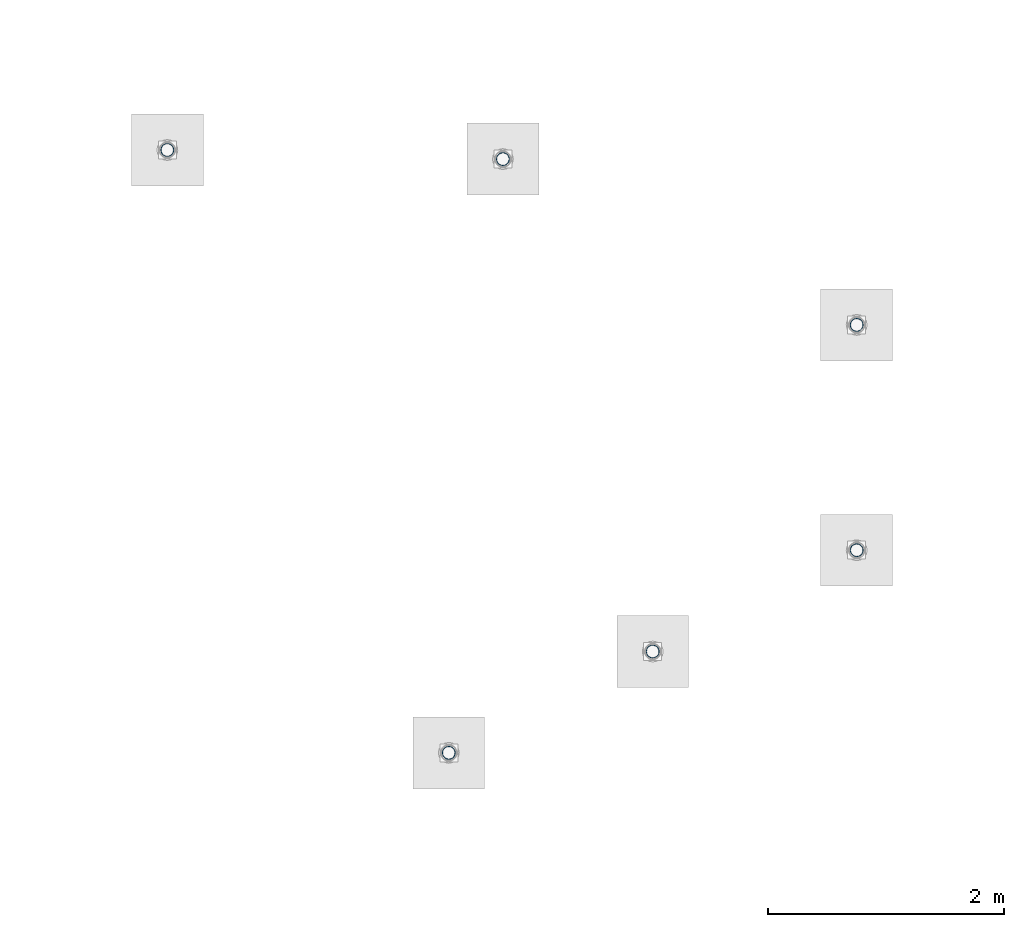
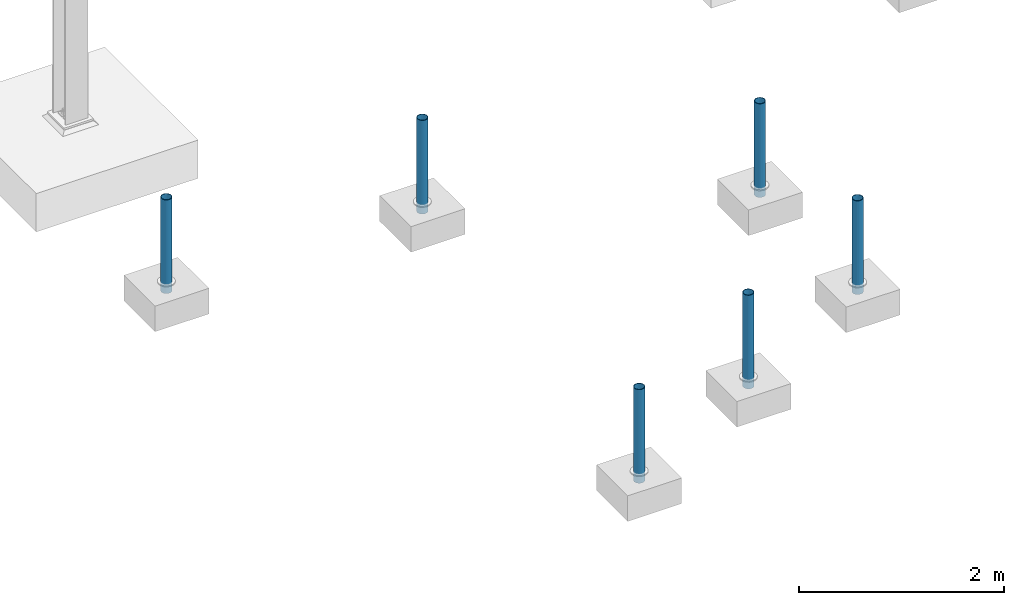
# One storey, part 1343 of 3843: 6 columns, 6 elements without a shape of their own.
"""IFC2X3 building model written with IfcOpenShell, lengths in millimetres."""

from ifc_helpers import new_model, si_unit, frame, origin_with_axes, place, context, subcontext, project, spatial, faceted_brep, material, type_object, element, aggregate, save


model = new_model("IFC2X3")

# Units and contexts
model_context = context("Model", 3, precision=1e-05, world=origin_with_axes())
body_context = subcontext(model_context, "Body", "Model", "MODEL_VIEW")
ifc_project = project(units=[si_unit("LENGTHUNIT", "METRE", prefix="MILLI"), si_unit("AREAUNIT", "SQUARE_METRE"), si_unit("VOLUMEUNIT", "CUBIC_METRE"), si_unit("MASSUNIT", "GRAM", prefix="KILO"), si_unit("TIMEUNIT", "SECOND"), si_unit("PLANEANGLEUNIT", "RADIAN"), si_unit("SOLIDANGLEUNIT", "STERADIAN"), si_unit("THERMODYNAMICTEMPERATUREUNIT", "DEGREE_CELSIUS"), si_unit("LUMINOUSINTENSITYUNIT", "LUMEN")], contexts=[model_context])

# Site, building, storey
site_placement = place(None, origin_with_axes())
site = spatial("IfcSite", under=ifc_project, at=site_placement, CompositionType="ELEMENT")
building_placement = place(site_placement, origin_with_axes())
building = spatial("IfcBuilding", under=site, at=building_placement, Name="Undefined", CompositionType="ELEMENT")
storey_placement = place(building_placement, origin_with_axes())
storey = spatial("IfcBuildingStorey", under=building, at=storey_placement, Name="Undefined", CompositionType="ELEMENT", Elevation=0.0)

# Assembly, column
assembly_1_placement = place(storey_placement, origin_with_axes())
assembly_1 = element("IfcElementAssembly", 1, at=assembly_1_placement, inside=storey, Name="PIPE_BOLLARD", AssemblyPlace="NOTDEFINED", PredefinedType="RIGID_FRAME")
ifc_material = material()
column_type = type_object("IfcColumnType", Name="PIPE4SCH40", PredefinedType="NOTDEFINED")
column_1_placement = place(assembly_1_placement, frame((1496.020312, 80588.048439, 30378.4), z_axis=(-1.0, 0.0, 0.0), x_axis=(0.0, 0.0, 1.0)))
column_1 = element("IfcColumn", 2, at=column_1_placement, type_object=column_type, material=ifc_material, Name="PIPE_BOLLARD", ObjectType="PIPE4SCH40", context=body_context, shape_type="Brep", body=[
    faceted_brep([(0.0, -51.1301999999996, 0.0), (0.0, -48.6277098894743, 15.8001007257844), (1117.6, -48.6277098894743, 15.8001007257844), (1117.6, -51.1301999999996, 0.0), (0.0, -41.3652007257897, 30.0535775067692), (1117.6, -41.3652007257897, 30.0535775067692), (0.0, -30.0535775067647, 41.3652007257915), (1117.6, -30.0535775067647, 41.3652007257915), (0.0, -15.8001007257899, 48.6277098894789), (1117.6, -15.8001007257899, 48.6277098894789), (0.0, 0.0, 51.1301999999996), (1117.6, 0.0, 51.1301999999996), (0.0, 15.8001007257899, 48.6277098894789), (1117.6, 15.8001007257899, 48.6277098894789), (0.0, 30.0535775067647, 41.3652007257915), (1117.6, 30.0535775067647, 41.3652007257915), (0.0, 41.3652007257897, 30.0535775067692), (1117.6, 41.3652007257897, 30.0535775067692), (0.0, 48.6277098894743, 15.8001007257844), (1117.6, 48.6277098894743, 15.8001007257844), (0.0, 51.1301999999996, 0.0), (1117.6, 51.1301999999996, 0.0), (0.0, 48.6277098894743, -15.8001007257844), (1117.6, 48.6277098894743, -15.8001007257844), (0.0, 41.3652007257897, -30.0535775067692), (1117.6, 41.3652007257897, -30.0535775067692), (0.0, 30.0535775067647, -41.3652007257915), (1117.6, 30.0535775067647, -41.3652007257915), (0.0, 15.8001007257899, -48.6277098894789), (1117.6, 15.8001007257899, -48.6277098894789), (0.0, 0.0, -51.1301999999996), (1117.6, 0.0, -51.1301999999996), (0.0, -15.8001007257899, -48.6277098894789), (1117.6, -15.8001007257899, -48.6277098894789), (0.0, -30.0535775067647, -41.3652007257915), (1117.6, -30.0535775067647, -41.3652007257915), (0.0, -41.3652007257897, -30.0535775067692), (1117.6, -41.3652007257897, -30.0535775067692), (0.0, -48.6277098894743, -15.8001007257844), (1117.6, -48.6277098894743, -15.8001007257844), (0.0, -57.1499999999996, 0.0), (0.0, -54.3528799062678, -17.6603212285263), (1117.6, -54.3528799062678, -17.6603212285263), (1117.6, -57.1499999999996, 0.0), (0.0, -46.2353212285279, -33.5919271685125), (1117.6, -46.2353212285279, -33.5919271685125), (0.0, -33.5919271685152, -46.2353212285234), (1117.6, -33.5919271685152, -46.2353212285234), (0.0, -17.6603212285281, -54.3528799062624), (1117.6, -17.6603212285281, -54.3528799062624), (0.0, 0.0, -57.1499999999942), (1117.6, 0.0, -57.1499999999942), (0.0, 17.6603212285281, -54.3528799062624), (1117.6, 17.6603212285281, -54.3528799062624), (0.0, 33.5919271685152, -46.2353212285234), (1117.6, 33.5919271685152, -46.2353212285234), (0.0, 46.2353212285279, -33.5919271685125), (1117.6, 46.2353212285279, -33.5919271685125), (0.0, 54.3528799062678, -17.6603212285263), (1117.6, 54.3528799062678, -17.6603212285263), (0.0, 57.1499999999996, 0.0), (1117.6, 57.1499999999996, 0.0), (0.0, 54.3528799062678, 17.6603212285263), (1117.6, 54.3528799062678, 17.6603212285263), (0.0, 46.2353212285279, 33.5919271685125), (1117.6, 46.2353212285279, 33.5919271685125), (0.0, 33.5919271685152, 46.2353212285234), (1117.6, 33.5919271685152, 46.2353212285234), (0.0, 17.6603212285281, 54.3528799062624), (1117.6, 17.6603212285281, 54.3528799062624), (0.0, 0.0, 57.1499999999942), (1117.6, 0.0, 57.1499999999942), (0.0, -17.6603212285281, 54.3528799062624), (1117.6, -17.6603212285281, 54.3528799062624), (0.0, -33.5919271685152, 46.2353212285234), (1117.6, -33.5919271685152, 46.2353212285234), (0.0, -46.2353212285279, 33.5919271685125), (1117.6, -46.2353212285279, 33.5919271685125), (0.0, -54.3528799062678, 17.6603212285263), (1117.6, -54.3528799062678, 17.6603212285263)], [[[0, 1, 2, 3]], [[1, 4, 5, 2]], [[4, 6, 7, 5]], [[6, 8, 9, 7]], [[8, 10, 11, 9]], [[10, 12, 13, 11]], [[12, 14, 15, 13]], [[14, 16, 17, 15]], [[16, 18, 19, 17]], [[18, 20, 21, 19]], [[20, 22, 23, 21]], [[22, 24, 25, 23]], [[24, 26, 27, 25]], [[26, 28, 29, 27]], [[28, 30, 31, 29]], [[30, 32, 33, 31]], [[32, 34, 35, 33]], [[34, 36, 37, 35]], [[36, 38, 39, 37]], [[38, 0, 3, 39]], [[40, 41, 42, 43]], [[41, 44, 45, 42]], [[44, 46, 47, 45]], [[46, 48, 49, 47]], [[48, 50, 51, 49]], [[50, 52, 53, 51]], [[52, 54, 55, 53]], [[54, 56, 57, 55]], [[56, 58, 59, 57]], [[58, 60, 61, 59]], [[60, 62, 63, 61]], [[62, 64, 65, 63]], [[64, 66, 67, 65]], [[66, 68, 69, 67]], [[68, 70, 71, 69]], [[70, 72, 73, 71]], [[72, 74, 75, 73]], [[74, 76, 77, 75]], [[76, 78, 79, 77]], [[78, 40, 43, 79]], [[45, 47, 49, 51, 53, 55, 57, 59, 61, 63, 65, 67, 69, 71, 73, 75, 77, 79, 43, 42], [5, 7, 9, 11, 13, 15, 17, 19, 21, 23, 25, 27, 29, 31, 33, 35, 37, 39, 3, 2]], [[78, 76, 74, 72, 70, 68, 66, 64, 62, 60, 58, 56, 54, 52, 50, 48, 46, 44, 41, 40], [38, 36, 34, 32, 30, 28, 26, 24, 22, 20, 18, 16, 14, 12, 10, 8, 6, 4, 1, 0]]]),
])
aggregate(assembly_1, [column_1])

assembly_2_placement = place(storey_placement, origin_with_axes())
assembly_2 = element("IfcElementAssembly", 3, at=assembly_2_placement, inside=storey, Name="PIPE_BOLLARD", AssemblyPlace="NOTDEFINED", PredefinedType="RIGID_FRAME")
column_2_placement = place(assembly_2_placement, frame((3224.807812, 81446.687501, 30378.4), z_axis=(-1.0, 0.0, 0.0), x_axis=(0.0, 0.0, 1.0)))
column_2 = element("IfcColumn", 4, at=column_2_placement, type_object=column_type, material=ifc_material, Name="PIPE_BOLLARD", ObjectType="PIPE4SCH40", context=body_context, shape_type="Brep", body=[
    faceted_brep([(0.0, -51.1301999999996, 0.0), (0.0, -48.6277098894743, 15.8001007257844), (1117.6, -48.6277098894743, 15.8001007257844), (1117.6, -51.1301999999996, 0.0), (0.0, -41.3652007257897, 30.0535775067692), (1117.6, -41.3652007257897, 30.0535775067692), (0.0, -30.0535775067647, 41.3652007257915), (1117.6, -30.0535775067647, 41.3652007257915), (0.0, -15.8001007257899, 48.6277098894789), (1117.6, -15.8001007257899, 48.6277098894789), (0.0, 0.0, 51.1301999999996), (1117.6, 0.0, 51.1301999999996), (0.0, 15.8001007257899, 48.6277098894789), (1117.6, 15.8001007257899, 48.6277098894789), (0.0, 30.0535775067647, 41.3652007257915), (1117.6, 30.0535775067647, 41.3652007257915), (0.0, 41.3652007257897, 30.0535775067692), (1117.6, 41.3652007257897, 30.0535775067692), (0.0, 48.6277098894743, 15.8001007257844), (1117.6, 48.6277098894743, 15.8001007257844), (0.0, 51.1301999999996, 0.0), (1117.6, 51.1301999999996, 0.0), (0.0, 48.6277098894743, -15.8001007257844), (1117.6, 48.6277098894743, -15.8001007257844), (0.0, 41.3652007257897, -30.0535775067692), (1117.6, 41.3652007257897, -30.0535775067692), (0.0, 30.0535775067647, -41.3652007257915), (1117.6, 30.0535775067647, -41.3652007257915), (0.0, 15.8001007257899, -48.6277098894789), (1117.6, 15.8001007257899, -48.6277098894789), (0.0, 0.0, -51.1301999999996), (1117.6, 0.0, -51.1301999999996), (0.0, -15.8001007257899, -48.6277098894789), (1117.6, -15.8001007257899, -48.6277098894789), (0.0, -30.0535775067647, -41.3652007257915), (1117.6, -30.0535775067647, -41.3652007257915), (0.0, -41.3652007257897, -30.0535775067692), (1117.6, -41.3652007257897, -30.0535775067692), (0.0, -48.6277098894743, -15.8001007257844), (1117.6, -48.6277098894743, -15.8001007257844), (0.0, -57.1499999999996, 0.0), (0.0, -54.3528799062678, -17.6603212285263), (1117.6, -54.3528799062678, -17.6603212285263), (1117.6, -57.1499999999996, 0.0), (0.0, -46.2353212285279, -33.5919271685125), (1117.6, -46.2353212285279, -33.5919271685125), (0.0, -33.5919271685152, -46.2353212285234), (1117.6, -33.5919271685152, -46.2353212285234), (0.0, -17.6603212285281, -54.3528799062624), (1117.6, -17.6603212285281, -54.3528799062624), (0.0, 0.0, -57.1499999999942), (1117.6, 0.0, -57.1499999999942), (0.0, 17.6603212285281, -54.3528799062624), (1117.6, 17.6603212285281, -54.3528799062624), (0.0, 33.5919271685152, -46.2353212285234), (1117.6, 33.5919271685152, -46.2353212285234), (0.0, 46.2353212285279, -33.5919271685125), (1117.6, 46.2353212285279, -33.5919271685125), (0.0, 54.3528799062678, -17.6603212285263), (1117.6, 54.3528799062678, -17.6603212285263), (0.0, 57.1499999999996, 0.0), (1117.6, 57.1499999999996, 0.0), (0.0, 54.3528799062678, 17.6603212285263), (1117.6, 54.3528799062678, 17.6603212285263), (0.0, 46.2353212285279, 33.5919271685125), (1117.6, 46.2353212285279, 33.5919271685125), (0.0, 33.5919271685152, 46.2353212285234), (1117.6, 33.5919271685152, 46.2353212285234), (0.0, 17.6603212285281, 54.3528799062624), (1117.6, 17.6603212285281, 54.3528799062624), (0.0, 0.0, 57.1499999999942), (1117.6, 0.0, 57.1499999999942), (0.0, -17.6603212285281, 54.3528799062624), (1117.6, -17.6603212285281, 54.3528799062624), (0.0, -33.5919271685152, 46.2353212285234), (1117.6, -33.5919271685152, 46.2353212285234), (0.0, -46.2353212285279, 33.5919271685125), (1117.6, -46.2353212285279, 33.5919271685125), (0.0, -54.3528799062678, 17.6603212285263), (1117.6, -54.3528799062678, 17.6603212285263)], [[[0, 1, 2, 3]], [[1, 4, 5, 2]], [[4, 6, 7, 5]], [[6, 8, 9, 7]], [[8, 10, 11, 9]], [[10, 12, 13, 11]], [[12, 14, 15, 13]], [[14, 16, 17, 15]], [[16, 18, 19, 17]], [[18, 20, 21, 19]], [[20, 22, 23, 21]], [[22, 24, 25, 23]], [[24, 26, 27, 25]], [[26, 28, 29, 27]], [[28, 30, 31, 29]], [[30, 32, 33, 31]], [[32, 34, 35, 33]], [[34, 36, 37, 35]], [[36, 38, 39, 37]], [[38, 0, 3, 39]], [[40, 41, 42, 43]], [[41, 44, 45, 42]], [[44, 46, 47, 45]], [[46, 48, 49, 47]], [[48, 50, 51, 49]], [[50, 52, 53, 51]], [[52, 54, 55, 53]], [[54, 56, 57, 55]], [[56, 58, 59, 57]], [[58, 60, 61, 59]], [[60, 62, 63, 61]], [[62, 64, 65, 63]], [[64, 66, 67, 65]], [[66, 68, 69, 67]], [[68, 70, 71, 69]], [[70, 72, 73, 71]], [[72, 74, 75, 73]], [[74, 76, 77, 75]], [[76, 78, 79, 77]], [[78, 40, 43, 79]], [[45, 47, 49, 51, 53, 55, 57, 59, 61, 63, 65, 67, 69, 71, 73, 75, 77, 79, 43, 42], [5, 7, 9, 11, 13, 15, 17, 19, 21, 23, 25, 27, 29, 31, 33, 35, 37, 39, 3, 2]], [[78, 76, 74, 72, 70, 68, 66, 64, 62, 60, 58, 56, 54, 52, 50, 48, 46, 44, 41, 40], [38, 36, 34, 32, 30, 28, 26, 24, 22, 20, 18, 16, 14, 12, 10, 8, 6, 4, 1, 0]]]),
])
aggregate(assembly_2, [column_2])

assembly_3_placement = place(storey_placement, origin_with_axes())
assembly_3 = element("IfcElementAssembly", 5, at=assembly_3_placement, inside=storey, Name="PIPE_BOLLARD", AssemblyPlace="NOTDEFINED", PredefinedType="RIGID_FRAME")
column_3_placement = place(assembly_3_placement, frame((4953.79375, 82305.525001, 30378.4), z_axis=(-1.0, 0.0, 0.0), x_axis=(0.0, 0.0, 1.0)))
column_3 = element("IfcColumn", 6, at=column_3_placement, type_object=column_type, material=ifc_material, Name="PIPE_BOLLARD", ObjectType="PIPE4SCH40", context=body_context, shape_type="Brep", body=[
    faceted_brep([(0.0, -51.1301999999996, 0.0), (0.0, -48.6277098894743, 15.8001007257844), (1117.6, -48.6277098894743, 15.8001007257844), (1117.6, -51.1301999999996, 0.0), (0.0, -41.3652007257897, 30.0535775067692), (1117.6, -41.3652007257897, 30.0535775067692), (0.0, -30.0535775067647, 41.3652007257915), (1117.6, -30.0535775067647, 41.3652007257915), (0.0, -15.8001007257899, 48.6277098894789), (1117.6, -15.8001007257899, 48.6277098894789), (0.0, 0.0, 51.1301999999996), (1117.6, 0.0, 51.1301999999996), (0.0, 15.8001007257899, 48.6277098894789), (1117.6, 15.8001007257899, 48.6277098894789), (0.0, 30.0535775067647, 41.3652007257915), (1117.6, 30.0535775067647, 41.3652007257915), (0.0, 41.3652007257897, 30.0535775067692), (1117.6, 41.3652007257897, 30.0535775067692), (0.0, 48.6277098894743, 15.8001007257844), (1117.6, 48.6277098894743, 15.8001007257844), (0.0, 51.1301999999996, 0.0), (1117.6, 51.1301999999996, 0.0), (0.0, 48.6277098894743, -15.8001007257844), (1117.6, 48.6277098894743, -15.8001007257844), (0.0, 41.3652007257897, -30.0535775067692), (1117.6, 41.3652007257897, -30.0535775067692), (0.0, 30.0535775067647, -41.3652007257915), (1117.6, 30.0535775067647, -41.3652007257915), (0.0, 15.8001007257899, -48.6277098894789), (1117.6, 15.8001007257899, -48.6277098894789), (0.0, 0.0, -51.1301999999996), (1117.6, 0.0, -51.1301999999996), (0.0, -15.8001007257899, -48.6277098894789), (1117.6, -15.8001007257899, -48.6277098894789), (0.0, -30.0535775067647, -41.3652007257915), (1117.6, -30.0535775067647, -41.3652007257915), (0.0, -41.3652007257897, -30.0535775067692), (1117.6, -41.3652007257897, -30.0535775067692), (0.0, -48.6277098894743, -15.8001007257844), (1117.6, -48.6277098894743, -15.8001007257844), (0.0, -57.1499999999996, 0.0), (0.0, -54.3528799062678, -17.6603212285263), (1117.6, -54.3528799062678, -17.6603212285263), (1117.6, -57.1499999999996, 0.0), (0.0, -46.2353212285279, -33.5919271685125), (1117.6, -46.2353212285279, -33.5919271685125), (0.0, -33.5919271685152, -46.2353212285234), (1117.6, -33.5919271685152, -46.2353212285234), (0.0, -17.6603212285281, -54.3528799062624), (1117.6, -17.6603212285281, -54.3528799062624), (0.0, 0.0, -57.1499999999942), (1117.6, 0.0, -57.1499999999942), (0.0, 17.6603212285281, -54.3528799062624), (1117.6, 17.6603212285281, -54.3528799062624), (0.0, 33.5919271685152, -46.2353212285234), (1117.6, 33.5919271685152, -46.2353212285234), (0.0, 46.2353212285279, -33.5919271685125), (1117.6, 46.2353212285279, -33.5919271685125), (0.0, 54.3528799062678, -17.6603212285263), (1117.6, 54.3528799062678, -17.6603212285263), (0.0, 57.1499999999996, 0.0), (1117.6, 57.1499999999996, 0.0), (0.0, 54.3528799062678, 17.6603212285263), (1117.6, 54.3528799062678, 17.6603212285263), (0.0, 46.2353212285279, 33.5919271685125), (1117.6, 46.2353212285279, 33.5919271685125), (0.0, 33.5919271685152, 46.2353212285234), (1117.6, 33.5919271685152, 46.2353212285234), (0.0, 17.6603212285281, 54.3528799062624), (1117.6, 17.6603212285281, 54.3528799062624), (0.0, 0.0, 57.1499999999942), (1117.6, 0.0, 57.1499999999942), (0.0, -17.6603212285281, 54.3528799062624), (1117.6, -17.6603212285281, 54.3528799062624), (0.0, -33.5919271685152, 46.2353212285234), (1117.6, -33.5919271685152, 46.2353212285234), (0.0, -46.2353212285279, 33.5919271685125), (1117.6, -46.2353212285279, 33.5919271685125), (0.0, -54.3528799062678, 17.6603212285263), (1117.6, -54.3528799062678, 17.6603212285263)], [[[0, 1, 2, 3]], [[1, 4, 5, 2]], [[4, 6, 7, 5]], [[6, 8, 9, 7]], [[8, 10, 11, 9]], [[10, 12, 13, 11]], [[12, 14, 15, 13]], [[14, 16, 17, 15]], [[16, 18, 19, 17]], [[18, 20, 21, 19]], [[20, 22, 23, 21]], [[22, 24, 25, 23]], [[24, 26, 27, 25]], [[26, 28, 29, 27]], [[28, 30, 31, 29]], [[30, 32, 33, 31]], [[32, 34, 35, 33]], [[34, 36, 37, 35]], [[36, 38, 39, 37]], [[38, 0, 3, 39]], [[40, 41, 42, 43]], [[41, 44, 45, 42]], [[44, 46, 47, 45]], [[46, 48, 49, 47]], [[48, 50, 51, 49]], [[50, 52, 53, 51]], [[52, 54, 55, 53]], [[54, 56, 57, 55]], [[56, 58, 59, 57]], [[58, 60, 61, 59]], [[60, 62, 63, 61]], [[62, 64, 65, 63]], [[64, 66, 67, 65]], [[66, 68, 69, 67]], [[68, 70, 71, 69]], [[70, 72, 73, 71]], [[72, 74, 75, 73]], [[74, 76, 77, 75]], [[76, 78, 79, 77]], [[78, 40, 43, 79]], [[45, 47, 49, 51, 53, 55, 57, 59, 61, 63, 65, 67, 69, 71, 73, 75, 77, 79, 43, 42], [5, 7, 9, 11, 13, 15, 17, 19, 21, 23, 25, 27, 29, 31, 33, 35, 37, 39, 3, 2]], [[78, 76, 74, 72, 70, 68, 66, 64, 62, 60, 58, 56, 54, 52, 50, 48, 46, 44, 41, 40], [38, 36, 34, 32, 30, 28, 26, 24, 22, 20, 18, 16, 14, 12, 10, 8, 6, 4, 1, 0]]]),
])
aggregate(assembly_3, [column_3])

assembly_4_placement = place(storey_placement, origin_with_axes())
assembly_4 = element("IfcElementAssembly", 7, at=assembly_4_placement, inside=storey, Name="PIPE_BOLLARD", AssemblyPlace="NOTDEFINED", PredefinedType="RIGID_FRAME")
column_4_placement = place(assembly_4_placement, frame((4953.79375, 84215.684376, 30378.4), z_axis=(-1.0, 0.0, 0.0), x_axis=(0.0, 0.0, 1.0)))
column_4 = element("IfcColumn", 8, at=column_4_placement, type_object=column_type, material=ifc_material, Name="PIPE_BOLLARD", ObjectType="PIPE4SCH40", context=body_context, shape_type="Brep", body=[
    faceted_brep([(0.0, -51.1301999999996, 0.0), (0.0, -48.6277098894743, 15.8001007257844), (1117.6, -48.6277098894743, 15.8001007257844), (1117.6, -51.1301999999996, 0.0), (0.0, -41.3652007257897, 30.0535775067692), (1117.6, -41.3652007257897, 30.0535775067692), (0.0, -30.0535775067647, 41.3652007257915), (1117.6, -30.0535775067647, 41.3652007257915), (0.0, -15.8001007257899, 48.6277098894789), (1117.6, -15.8001007257899, 48.6277098894789), (0.0, 0.0, 51.1301999999996), (1117.6, 0.0, 51.1301999999996), (0.0, 15.8001007257899, 48.6277098894789), (1117.6, 15.8001007257899, 48.6277098894789), (0.0, 30.0535775067647, 41.3652007257915), (1117.6, 30.0535775067647, 41.3652007257915), (0.0, 41.3652007257897, 30.0535775067692), (1117.6, 41.3652007257897, 30.0535775067692), (0.0, 48.6277098894743, 15.8001007257844), (1117.6, 48.6277098894743, 15.8001007257844), (0.0, 51.1301999999996, 0.0), (1117.6, 51.1301999999996, 0.0), (0.0, 48.6277098894743, -15.8001007257844), (1117.6, 48.6277098894743, -15.8001007257844), (0.0, 41.3652007257897, -30.0535775067692), (1117.6, 41.3652007257897, -30.0535775067692), (0.0, 30.0535775067647, -41.3652007257915), (1117.6, 30.0535775067647, -41.3652007257915), (0.0, 15.8001007257899, -48.6277098894789), (1117.6, 15.8001007257899, -48.6277098894789), (0.0, 0.0, -51.1301999999996), (1117.6, 0.0, -51.1301999999996), (0.0, -15.8001007257899, -48.6277098894789), (1117.6, -15.8001007257899, -48.6277098894789), (0.0, -30.0535775067647, -41.3652007257915), (1117.6, -30.0535775067647, -41.3652007257915), (0.0, -41.3652007257897, -30.0535775067692), (1117.6, -41.3652007257897, -30.0535775067692), (0.0, -48.6277098894743, -15.8001007257844), (1117.6, -48.6277098894743, -15.8001007257844), (0.0, -57.1499999999996, 0.0), (0.0, -54.3528799062678, -17.6603212285263), (1117.6, -54.3528799062678, -17.6603212285263), (1117.6, -57.1499999999996, 0.0), (0.0, -46.2353212285279, -33.5919271685125), (1117.6, -46.2353212285279, -33.5919271685125), (0.0, -33.5919271685152, -46.2353212285234), (1117.6, -33.5919271685152, -46.2353212285234), (0.0, -17.6603212285281, -54.3528799062624), (1117.6, -17.6603212285281, -54.3528799062624), (0.0, 0.0, -57.1499999999942), (1117.6, 0.0, -57.1499999999942), (0.0, 17.6603212285281, -54.3528799062624), (1117.6, 17.6603212285281, -54.3528799062624), (0.0, 33.5919271685152, -46.2353212285234), (1117.6, 33.5919271685152, -46.2353212285234), (0.0, 46.2353212285279, -33.5919271685125), (1117.6, 46.2353212285279, -33.5919271685125), (0.0, 54.3528799062678, -17.6603212285263), (1117.6, 54.3528799062678, -17.6603212285263), (0.0, 57.1499999999996, 0.0), (1117.6, 57.1499999999996, 0.0), (0.0, 54.3528799062678, 17.6603212285263), (1117.6, 54.3528799062678, 17.6603212285263), (0.0, 46.2353212285279, 33.5919271685125), (1117.6, 46.2353212285279, 33.5919271685125), (0.0, 33.5919271685152, 46.2353212285234), (1117.6, 33.5919271685152, 46.2353212285234), (0.0, 17.6603212285281, 54.3528799062624), (1117.6, 17.6603212285281, 54.3528799062624), (0.0, 0.0, 57.1499999999942), (1117.6, 0.0, 57.1499999999942), (0.0, -17.6603212285281, 54.3528799062624), (1117.6, -17.6603212285281, 54.3528799062624), (0.0, -33.5919271685152, 46.2353212285234), (1117.6, -33.5919271685152, 46.2353212285234), (0.0, -46.2353212285279, 33.5919271685125), (1117.6, -46.2353212285279, 33.5919271685125), (0.0, -54.3528799062678, 17.6603212285263), (1117.6, -54.3528799062678, 17.6603212285263)], [[[0, 1, 2, 3]], [[1, 4, 5, 2]], [[4, 6, 7, 5]], [[6, 8, 9, 7]], [[8, 10, 11, 9]], [[10, 12, 13, 11]], [[12, 14, 15, 13]], [[14, 16, 17, 15]], [[16, 18, 19, 17]], [[18, 20, 21, 19]], [[20, 22, 23, 21]], [[22, 24, 25, 23]], [[24, 26, 27, 25]], [[26, 28, 29, 27]], [[28, 30, 31, 29]], [[30, 32, 33, 31]], [[32, 34, 35, 33]], [[34, 36, 37, 35]], [[36, 38, 39, 37]], [[38, 0, 3, 39]], [[40, 41, 42, 43]], [[41, 44, 45, 42]], [[44, 46, 47, 45]], [[46, 48, 49, 47]], [[48, 50, 51, 49]], [[50, 52, 53, 51]], [[52, 54, 55, 53]], [[54, 56, 57, 55]], [[56, 58, 59, 57]], [[58, 60, 61, 59]], [[60, 62, 63, 61]], [[62, 64, 65, 63]], [[64, 66, 67, 65]], [[66, 68, 69, 67]], [[68, 70, 71, 69]], [[70, 72, 73, 71]], [[72, 74, 75, 73]], [[74, 76, 77, 75]], [[76, 78, 79, 77]], [[78, 40, 43, 79]], [[45, 47, 49, 51, 53, 55, 57, 59, 61, 63, 65, 67, 69, 71, 73, 75, 77, 79, 43, 42], [5, 7, 9, 11, 13, 15, 17, 19, 21, 23, 25, 27, 29, 31, 33, 35, 37, 39, 3, 2]], [[78, 76, 74, 72, 70, 68, 66, 64, 62, 60, 58, 56, 54, 52, 50, 48, 46, 44, 41, 40], [38, 36, 34, 32, 30, 28, 26, 24, 22, 20, 18, 16, 14, 12, 10, 8, 6, 4, 1, 0]]]),
])
aggregate(assembly_4, [column_4])

assembly_5_placement = place(storey_placement, origin_with_axes())
assembly_5 = element("IfcElementAssembly", 9, at=assembly_5_placement, inside=storey, Name="PIPE_BOLLARD", AssemblyPlace="NOTDEFINED", PredefinedType="RIGID_FRAME")
column_5_placement = place(assembly_5_placement, frame((1954.609375, 85621.018751, 30378.4), z_axis=(-1.0, 0.0, 0.0), x_axis=(0.0, 0.0, 1.0)))
column_5 = element("IfcColumn", 10, at=column_5_placement, type_object=column_type, material=ifc_material, Name="PIPE_BOLLARD", ObjectType="PIPE4SCH40", context=body_context, shape_type="Brep", body=[
    faceted_brep([(0.0, -51.1301999999996, 0.0), (0.0, -48.6277098894743, 15.8001007257844), (1117.6, -48.6277098894743, 15.8001007257844), (1117.6, -51.1301999999996, 0.0), (0.0, -41.3652007257897, 30.0535775067692), (1117.6, -41.3652007257897, 30.0535775067692), (0.0, -30.0535775067647, 41.3652007257915), (1117.6, -30.0535775067647, 41.3652007257915), (0.0, -15.8001007257899, 48.6277098894789), (1117.6, -15.8001007257899, 48.6277098894789), (0.0, 0.0, 51.1301999999996), (1117.6, 0.0, 51.1301999999996), (0.0, 15.8001007257899, 48.6277098894789), (1117.6, 15.8001007257899, 48.6277098894789), (0.0, 30.0535775067647, 41.3652007257915), (1117.6, 30.0535775067647, 41.3652007257915), (0.0, 41.3652007257897, 30.0535775067692), (1117.6, 41.3652007257897, 30.0535775067692), (0.0, 48.6277098894743, 15.8001007257844), (1117.6, 48.6277098894743, 15.8001007257844), (0.0, 51.1301999999996, 0.0), (1117.6, 51.1301999999996, 0.0), (0.0, 48.6277098894743, -15.8001007257844), (1117.6, 48.6277098894743, -15.8001007257844), (0.0, 41.3652007257897, -30.0535775067692), (1117.6, 41.3652007257897, -30.0535775067692), (0.0, 30.0535775067647, -41.3652007257915), (1117.6, 30.0535775067647, -41.3652007257915), (0.0, 15.8001007257899, -48.6277098894789), (1117.6, 15.8001007257899, -48.6277098894789), (0.0, 0.0, -51.1301999999996), (1117.6, 0.0, -51.1301999999996), (0.0, -15.8001007257899, -48.6277098894789), (1117.6, -15.8001007257899, -48.6277098894789), (0.0, -30.0535775067647, -41.3652007257915), (1117.6, -30.0535775067647, -41.3652007257915), (0.0, -41.3652007257897, -30.0535775067692), (1117.6, -41.3652007257897, -30.0535775067692), (0.0, -48.6277098894743, -15.8001007257844), (1117.6, -48.6277098894743, -15.8001007257844), (0.0, -57.1499999999996, 0.0), (0.0, -54.3528799062678, -17.6603212285263), (1117.6, -54.3528799062678, -17.6603212285263), (1117.6, -57.1499999999996, 0.0), (0.0, -46.2353212285279, -33.5919271685125), (1117.6, -46.2353212285279, -33.5919271685125), (0.0, -33.5919271685152, -46.2353212285234), (1117.6, -33.5919271685152, -46.2353212285234), (0.0, -17.6603212285281, -54.3528799062624), (1117.6, -17.6603212285281, -54.3528799062624), (0.0, 0.0, -57.1499999999942), (1117.6, 0.0, -57.1499999999942), (0.0, 17.6603212285281, -54.3528799062624), (1117.6, 17.6603212285281, -54.3528799062624), (0.0, 33.5919271685152, -46.2353212285234), (1117.6, 33.5919271685152, -46.2353212285234), (0.0, 46.2353212285279, -33.5919271685125), (1117.6, 46.2353212285279, -33.5919271685125), (0.0, 54.3528799062678, -17.6603212285263), (1117.6, 54.3528799062678, -17.6603212285263), (0.0, 57.1499999999996, 0.0), (1117.6, 57.1499999999996, 0.0), (0.0, 54.3528799062678, 17.6603212285263), (1117.6, 54.3528799062678, 17.6603212285263), (0.0, 46.2353212285279, 33.5919271685125), (1117.6, 46.2353212285279, 33.5919271685125), (0.0, 33.5919271685152, 46.2353212285234), (1117.6, 33.5919271685152, 46.2353212285234), (0.0, 17.6603212285281, 54.3528799062624), (1117.6, 17.6603212285281, 54.3528799062624), (0.0, 0.0, 57.1499999999942), (1117.6, 0.0, 57.1499999999942), (0.0, -17.6603212285281, 54.3528799062624), (1117.6, -17.6603212285281, 54.3528799062624), (0.0, -33.5919271685152, 46.2353212285234), (1117.6, -33.5919271685152, 46.2353212285234), (0.0, -46.2353212285279, 33.5919271685125), (1117.6, -46.2353212285279, 33.5919271685125), (0.0, -54.3528799062678, 17.6603212285263), (1117.6, -54.3528799062678, 17.6603212285263)], [[[0, 1, 2, 3]], [[1, 4, 5, 2]], [[4, 6, 7, 5]], [[6, 8, 9, 7]], [[8, 10, 11, 9]], [[10, 12, 13, 11]], [[12, 14, 15, 13]], [[14, 16, 17, 15]], [[16, 18, 19, 17]], [[18, 20, 21, 19]], [[20, 22, 23, 21]], [[22, 24, 25, 23]], [[24, 26, 27, 25]], [[26, 28, 29, 27]], [[28, 30, 31, 29]], [[30, 32, 33, 31]], [[32, 34, 35, 33]], [[34, 36, 37, 35]], [[36, 38, 39, 37]], [[38, 0, 3, 39]], [[40, 41, 42, 43]], [[41, 44, 45, 42]], [[44, 46, 47, 45]], [[46, 48, 49, 47]], [[48, 50, 51, 49]], [[50, 52, 53, 51]], [[52, 54, 55, 53]], [[54, 56, 57, 55]], [[56, 58, 59, 57]], [[58, 60, 61, 59]], [[60, 62, 63, 61]], [[62, 64, 65, 63]], [[64, 66, 67, 65]], [[66, 68, 69, 67]], [[68, 70, 71, 69]], [[70, 72, 73, 71]], [[72, 74, 75, 73]], [[74, 76, 77, 75]], [[76, 78, 79, 77]], [[78, 40, 43, 79]], [[45, 47, 49, 51, 53, 55, 57, 59, 61, 63, 65, 67, 69, 71, 73, 75, 77, 79, 43, 42], [5, 7, 9, 11, 13, 15, 17, 19, 21, 23, 25, 27, 29, 31, 33, 35, 37, 39, 3, 2]], [[78, 76, 74, 72, 70, 68, 66, 64, 62, 60, 58, 56, 54, 52, 50, 48, 46, 44, 41, 40], [38, 36, 34, 32, 30, 28, 26, 24, 22, 20, 18, 16, 14, 12, 10, 8, 6, 4, 1, 0]]]),
])
aggregate(assembly_5, [column_5])

assembly_6_placement = place(storey_placement, origin_with_axes())
assembly_6 = element("IfcElementAssembly", 11, at=assembly_6_placement, inside=storey, Name="PIPE_BOLLARD", AssemblyPlace="NOTDEFINED", PredefinedType="RIGID_FRAME")
column_6_placement = place(assembly_6_placement, frame((-889.992187999998, 85698.210939, 30378.4), z_axis=(-1.0, 0.0, 0.0), x_axis=(0.0, 0.0, 1.0)))
column_6 = element("IfcColumn", 12, at=column_6_placement, type_object=column_type, material=ifc_material, Name="PIPE_BOLLARD", ObjectType="PIPE4SCH40", context=body_context, shape_type="Brep", body=[
    faceted_brep([(0.0, -51.1301999999996, 0.0), (0.0, -48.6277098894743, 15.8001007257844), (1117.6, -48.6277098894743, 15.8001007257844), (1117.6, -51.1301999999996, 0.0), (0.0, -41.3652007257897, 30.0535775067692), (1117.6, -41.3652007257897, 30.0535775067692), (0.0, -30.0535775067647, 41.3652007257915), (1117.6, -30.0535775067647, 41.3652007257915), (0.0, -15.8001007257899, 48.6277098894789), (1117.6, -15.8001007257899, 48.6277098894789), (0.0, 0.0, 51.1301999999996), (1117.6, 0.0, 51.1301999999996), (0.0, 15.8001007257899, 48.6277098894789), (1117.6, 15.8001007257899, 48.6277098894789), (0.0, 30.0535775067647, 41.3652007257915), (1117.6, 30.0535775067647, 41.3652007257915), (0.0, 41.3652007257897, 30.0535775067692), (1117.6, 41.3652007257897, 30.0535775067692), (0.0, 48.6277098894743, 15.8001007257844), (1117.6, 48.6277098894743, 15.8001007257844), (0.0, 51.1301999999996, 0.0), (1117.6, 51.1301999999996, 0.0), (0.0, 48.6277098894743, -15.8001007257844), (1117.6, 48.6277098894743, -15.8001007257844), (0.0, 41.3652007257897, -30.0535775067692), (1117.6, 41.3652007257897, -30.0535775067692), (0.0, 30.0535775067647, -41.3652007257915), (1117.6, 30.0535775067647, -41.3652007257915), (0.0, 15.8001007257899, -48.6277098894789), (1117.6, 15.8001007257899, -48.6277098894789), (0.0, 0.0, -51.1301999999996), (1117.6, 0.0, -51.1301999999996), (0.0, -15.8001007257899, -48.6277098894789), (1117.6, -15.8001007257899, -48.6277098894789), (0.0, -30.0535775067647, -41.3652007257915), (1117.6, -30.0535775067647, -41.3652007257915), (0.0, -41.3652007257897, -30.0535775067692), (1117.6, -41.3652007257897, -30.0535775067692), (0.0, -48.6277098894743, -15.8001007257844), (1117.6, -48.6277098894743, -15.8001007257844), (0.0, -57.1499999999996, 0.0), (0.0, -54.3528799062678, -17.6603212285263), (1117.6, -54.3528799062678, -17.6603212285263), (1117.6, -57.1499999999996, 0.0), (0.0, -46.2353212285279, -33.5919271685125), (1117.6, -46.2353212285279, -33.5919271685125), (0.0, -33.5919271685152, -46.2353212285234), (1117.6, -33.5919271685152, -46.2353212285234), (0.0, -17.6603212285281, -54.3528799062624), (1117.6, -17.6603212285281, -54.3528799062624), (0.0, 0.0, -57.1499999999942), (1117.6, 0.0, -57.1499999999942), (0.0, 17.6603212285281, -54.3528799062624), (1117.6, 17.6603212285281, -54.3528799062624), (0.0, 33.5919271685152, -46.2353212285234), (1117.6, 33.5919271685152, -46.2353212285234), (0.0, 46.2353212285279, -33.5919271685125), (1117.6, 46.2353212285279, -33.5919271685125), (0.0, 54.3528799062678, -17.6603212285263), (1117.6, 54.3528799062678, -17.6603212285263), (0.0, 57.1499999999996, 0.0), (1117.6, 57.1499999999996, 0.0), (0.0, 54.3528799062678, 17.6603212285263), (1117.6, 54.3528799062678, 17.6603212285263), (0.0, 46.2353212285279, 33.5919271685125), (1117.6, 46.2353212285279, 33.5919271685125), (0.0, 33.5919271685152, 46.2353212285234), (1117.6, 33.5919271685152, 46.2353212285234), (0.0, 17.6603212285281, 54.3528799062624), (1117.6, 17.6603212285281, 54.3528799062624), (0.0, 0.0, 57.1499999999942), (1117.6, 0.0, 57.1499999999942), (0.0, -17.6603212285281, 54.3528799062624), (1117.6, -17.6603212285281, 54.3528799062624), (0.0, -33.5919271685152, 46.2353212285234), (1117.6, -33.5919271685152, 46.2353212285234), (0.0, -46.2353212285279, 33.5919271685125), (1117.6, -46.2353212285279, 33.5919271685125), (0.0, -54.3528799062678, 17.6603212285263), (1117.6, -54.3528799062678, 17.6603212285263)], [[[0, 1, 2, 3]], [[1, 4, 5, 2]], [[4, 6, 7, 5]], [[6, 8, 9, 7]], [[8, 10, 11, 9]], [[10, 12, 13, 11]], [[12, 14, 15, 13]], [[14, 16, 17, 15]], [[16, 18, 19, 17]], [[18, 20, 21, 19]], [[20, 22, 23, 21]], [[22, 24, 25, 23]], [[24, 26, 27, 25]], [[26, 28, 29, 27]], [[28, 30, 31, 29]], [[30, 32, 33, 31]], [[32, 34, 35, 33]], [[34, 36, 37, 35]], [[36, 38, 39, 37]], [[38, 0, 3, 39]], [[40, 41, 42, 43]], [[41, 44, 45, 42]], [[44, 46, 47, 45]], [[46, 48, 49, 47]], [[48, 50, 51, 49]], [[50, 52, 53, 51]], [[52, 54, 55, 53]], [[54, 56, 57, 55]], [[56, 58, 59, 57]], [[58, 60, 61, 59]], [[60, 62, 63, 61]], [[62, 64, 65, 63]], [[64, 66, 67, 65]], [[66, 68, 69, 67]], [[68, 70, 71, 69]], [[70, 72, 73, 71]], [[72, 74, 75, 73]], [[74, 76, 77, 75]], [[76, 78, 79, 77]], [[78, 40, 43, 79]], [[45, 47, 49, 51, 53, 55, 57, 59, 61, 63, 65, 67, 69, 71, 73, 75, 77, 79, 43, 42], [5, 7, 9, 11, 13, 15, 17, 19, 21, 23, 25, 27, 29, 31, 33, 35, 37, 39, 3, 2]], [[78, 76, 74, 72, 70, 68, 66, 64, 62, 60, 58, 56, 54, 52, 50, 48, 46, 44, 41, 40], [38, 36, 34, 32, 30, 28, 26, 24, 22, 20, 18, 16, 14, 12, 10, 8, 6, 4, 1, 0]]]),
])
aggregate(assembly_6, [column_6])

save(model, "model.ifc")
